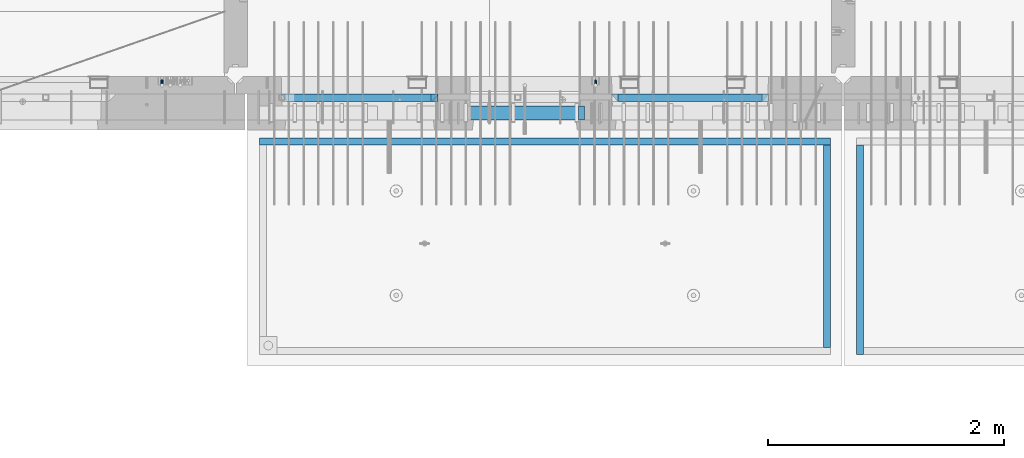
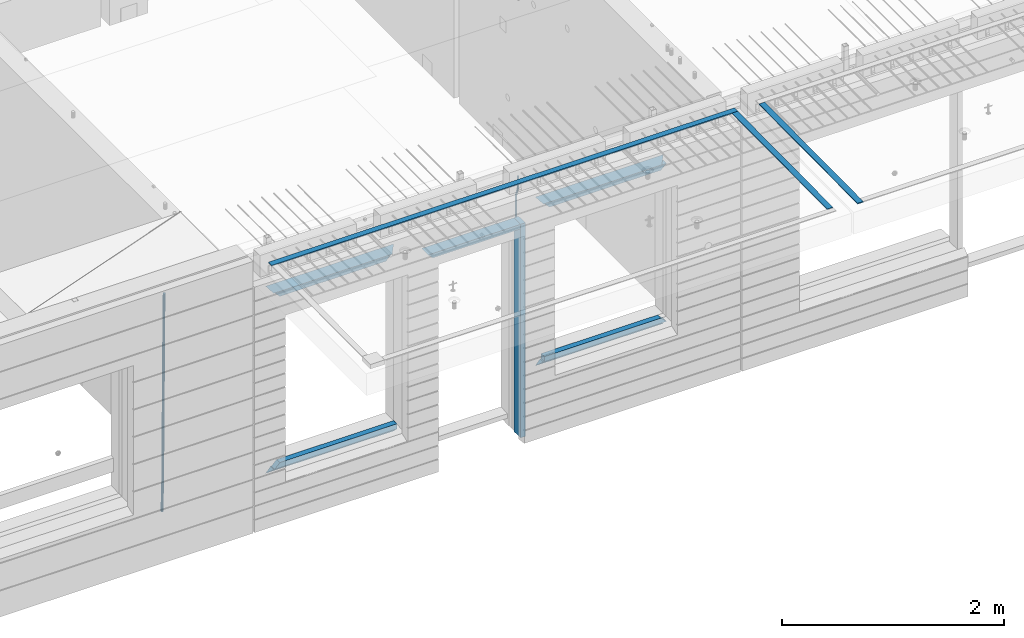
# One storey, part 96 of 349: 15 beams, 4 elements without a shape of their own.
"""IFC2X3 building model written with IfcOpenShell, lengths in millimetres."""

from ifc_helpers import new_model, si_unit, frame, origin_with_axes, place, context, subcontext, project, spatial, faceted_brep, material, type_object, element, aggregate, save


model = new_model("IFC2X3")

# Units and contexts
model_context = context("Model", 3, precision=1e-05, world=origin_with_axes())
body_context = subcontext(model_context, "Body", "Model", "MODEL_VIEW")
ifc_project = project(units=[si_unit("LENGTHUNIT", "METRE", prefix="MILLI"), si_unit("AREAUNIT", "SQUARE_METRE"), si_unit("VOLUMEUNIT", "CUBIC_METRE"), si_unit("MASSUNIT", "GRAM", prefix="KILO"), si_unit("TIMEUNIT", "SECOND"), si_unit("PLANEANGLEUNIT", "RADIAN"), si_unit("SOLIDANGLEUNIT", "STERADIAN"), si_unit("THERMODYNAMICTEMPERATUREUNIT", "DEGREE_CELSIUS"), si_unit("LUMINOUSINTENSITYUNIT", "LUMEN")], contexts=[model_context])

# Site, building, storey
site_placement = place(None, origin_with_axes())
site = spatial("IfcSite", under=ifc_project, at=site_placement, CompositionType="ELEMENT")
building_placement = place(site_placement, origin_with_axes())
building = spatial("IfcBuilding", under=site, at=building_placement, CompositionType="ELEMENT")
storey_placement = place(building_placement, origin_with_axes())
storey = spatial("IfcBuildingStorey", under=building, at=storey_placement, Name="4", CompositionType="ELEMENT", Elevation=0.0)

# Assembly, beam
assembly_1_placement = place(storey_placement, origin_with_axes())
assembly_1 = element("IfcElementAssembly", 1, at=assembly_1_placement, inside=storey, AssemblyPlace="NOTDEFINED", PredefinedType="REINFORCEMENT_UNIT")
ifc_material_1 = material()
beam_type_1 = type_object("IfcBeamType", Name="D20", PredefinedType="NOTDEFINED")
beam_1_placement = place(assembly_1_placement, frame((19710.0073333522, 7925.0, 93407.5000058722), z_axis=(0.000415599999849905, 0.999999913638203, 4.76000000899737e-07), x_axis=(0.0, 0.0, -1.0)))
beam_1 = element("IfcBeam", 2, at=beam_1_placement, type_object=beam_type_1, material=ifc_material_1, Name="JM20", ObjectType="D20", context=body_context, shape_type="Brep", body=[
    faceted_brep([(0.0, -10.0, 0.0), (-4.19531716033816e-08, -7.07106781186667, -7.07106781187031), (113.248091332178, -7.0710684840451, -7.0710678117357), (113.248091314759, -10.0000006713562, -2.51020537689328e-10), (0.0, 0.0, -10.0), (113.248091374131, -6.72178430249915e-07, -9.99999999986903), (4.196772351861e-08, 7.07106781186303, -7.07106781186667), (113.248091416113, 7.07106713968824, -7.07106781173934), (0.0, 10.0, 0.0), (113.248091433488, 9.99999932782521, 1.30967237055302e-10), (4.196772351861e-08, 7.07106781185939, 7.07106781185939), (113.248091416113, 7.0710671396846, 7.071067811994), (0.0, 0.0, 10.0), (113.248091374131, -6.72174792271107e-07, 10.0000000001273), (-4.19531716033816e-08, -7.07106781187031, 7.07106781185939), (113.248091332178, -7.0710684840451, 7.071067811994), (130.699843527167, -7.06993249763036, -4.33745683788584), (128.538066582521, -9.99900540317321, 2.39499413731755), (131.594536475241, 0.00119355250353692, -7.12624594330919), (130.698046432328, 7.07220300913468, -4.33773834422391), (128.535525107087, 10.0009944322555, 2.39459602660281), (126.373748162892, 7.07192152754578, 9.1270470011732), (125.479055214906, 0.000795477419160306, 11.9158361066184), (126.37554525779, -7.07021397921199, 9.12732850753673), (240.336258550378, -7.05529970173666, 30.8729495437874), (238.174481606227, -9.98437260450009, 37.6054005176375), (241.230951498423, 0.0158263482953771, 28.0841604381058), (240.334461455612, 7.0868358050102, 30.8726680369582), (238.171940130502, 10.0156272283348, 37.6050024077231), (236.010163186409, 7.08655432384694, 44.3374533824244), (235.115470238379, 0.0154282738185429, 47.1262424881097), (236.011960281176, -7.05558118289991, 44.3377348892536), (253.461915329972, -7.05444528127919, 32.9289287376414), (253.46191532613, -9.98337746617108, 39.9999965521893), (253.461915339081, 0.0166225284556276, 29.9999965443676), (253.461915348205, 7.08769034247234, 32.9289287273205), (253.461915352003, 10.0166225357716, 39.9999965370152), (253.461915348293, 7.08769035281148, 47.0710643509774), (253.461915339183, 0.0166225430875784, 49.999996544273), (253.46191533003, -7.05444527093641, 47.0710643613093), (1617.47998045172, -7.05444857276962, 32.9289287369675), (1617.47998044467, -9.98338075699212, 39.9999965504549), (1617.47998046874, 0.0166192374708771, 29.9999965449206), (1617.47998048575, 7.08768705096008, 32.9289287291404), (1617.47998049279, 10.0166192430079, 39.9999965393854), (1617.47998048575, 7.08768705878902, 47.071064352871), (1617.47998046874, 0.0166192485448846, 49.9999965449197), (1617.47998045172, -7.05444856494069, 47.0710643606981)], [[[0, 1, 2, 3]], [[1, 4, 5, 2]], [[4, 6, 7, 5]], [[6, 8, 9, 7]], [[8, 10, 11, 9]], [[10, 12, 13, 11]], [[12, 14, 15, 13]], [[14, 0, 3, 15]], [[14, 12, 10, 8, 6, 4, 1, 0]], [[3, 2, 16, 17]], [[2, 5, 18, 16]], [[5, 7, 19, 18]], [[7, 9, 20, 19]], [[9, 11, 21, 20]], [[11, 13, 22, 21]], [[13, 15, 23, 22]], [[15, 3, 17, 23]], [[17, 16, 24, 25]], [[16, 18, 26, 24]], [[18, 19, 27, 26]], [[19, 20, 28, 27]], [[20, 21, 29, 28]], [[21, 22, 30, 29]], [[22, 23, 31, 30]], [[23, 17, 25, 31]], [[25, 24, 32, 33]], [[24, 26, 34, 32]], [[26, 27, 35, 34]], [[27, 28, 36, 35]], [[28, 29, 37, 36]], [[29, 30, 38, 37]], [[30, 31, 39, 38]], [[31, 25, 33, 39]], [[33, 32, 40, 41]], [[32, 34, 42, 40]], [[34, 35, 43, 42]], [[35, 36, 44, 43]], [[36, 37, 45, 44]], [[37, 38, 46, 45]], [[38, 39, 47, 46]], [[39, 33, 41, 47]], [[42, 43, 44, 45, 46, 47, 41, 40]]]),
])

assembly_2_placement = place(storey_placement, origin_with_axes())
assembly_2 = element("IfcElementAssembly", 3, at=assembly_2_placement, inside=storey, AssemblyPlace="NOTDEFINED", PredefinedType="REINFORCEMENT_UNIT")
beam_type_2 = type_object("IfcBeamType", Name="D25", PredefinedType="NOTDEFINED")
beam_2_placement = place(assembly_2_placement, frame((16034.9999999961, 7965.00000227913, 90990.0), z_axis=(0.00020576299992186, -0.999642804629538, -0.0267249099901004), x_axis=(-4.30000201928125e-08, -0.0267249099948059, 0.999642825806181)))
beam_2 = element("IfcBeam", 4, at=beam_2_placement, type_object=beam_type_2, material=ifc_material_1, Name="JM25", ObjectType="D25", context=body_context, shape_type="Brep", body=[
    faceted_brep([(-7.41420080885291e-08, -12.5, -3.63797880709171e-12), (-6.42030499875546e-08, -10.8253175473074, -6.25000000000364), (60.4103898235917, -10.8253175318459, -6.2499999938409), (60.4103898269532, -12.4999999845422, 6.16273609921336e-09), (-3.70782800018787e-08, -6.25000000000364, -10.8253175473074), (60.4103898202884, -6.24999998454587, -10.8253175411446), (-1.45519152283669e-11, -3.63797880709171e-12, -12.5), (60.4103898179019, 1.54577719513327e-08, -12.4999999938373), (3.70637280866504e-08, 6.25, -10.8253175473074), (60.410389817087, 6.25000001545777, -10.825317541141), (6.42030499875546e-08, 10.8253175473001, -6.25000000000364), (60.410389818062, 10.8253175627578, -6.24999999383726), (7.41420080885291e-08, 12.4999999999927, 0.0), (60.4103898205503, 12.5000000154541, 6.16273609921336e-09), (6.42176019027829e-08, 10.8253175473001, 6.24999999999636), (60.4103898238973, 10.8253175627651, 6.2500000061591), (3.70928319171071e-08, 6.24999999999636, 10.8253175473037), (60.4103898272151, 6.25000001546141, 10.8253175534664), (1.45519152283669e-11, -3.63797880709171e-12, 12.4999999999964), (60.4103898296162, 1.54541339725256e-08, 12.5000000061591), (-3.7049176171422e-08, -6.25000000000364, 10.8253175473001), (60.4103898304165, -6.24999998454587, 10.8253175534701), (-6.41884980723262e-08, -10.8253175473074, 6.25), (60.4103898294561, -10.8253175318459, 6.25000000616637), (61.0324985728803, -10.8253175316895, -6.24999999377542), (60.991802792938, -12.4999999843931, 6.22458173893392e-09), (61.0622854283865, -6.24999998437852, -10.8253175410755), (61.0731819955545, 1.5628756955266e-08, -12.4999999937718), (61.0622685480339, 6.25000001562512, -10.8253175410791), (61.032469335245, 10.8253175629216, -6.24999999377178), (60.9917690322181, 12.5000000156033, 6.22458173893392e-09), (60.9510732522613, 10.8253175629034, 6.25000000621731), (60.9212863967696, 6.25000001558874, 10.8253175535247), (60.9103898296162, 1.55814632307738e-08, 12.5000000062137), (60.9213032771368, -6.24999998441126, 10.8253175535174), (60.9511024898966, -10.8253175317113, 6.25000000621731), (61.6545545670233, -10.8253158516927, -6.24189838219536), (61.573166454793, -12.499998414296, 0.00757164385504439), (61.7141257553885, -6.24999822394238, -10.8168280205282), (61.7359179680789, 1.80548886419274e-06, -12.491368569139), (61.7140919992817, 6.25000177601396, -10.8168282403167), (61.6544960997562, 10.8253192428383, -6.2418987628771), (61.5730989426083, 12.5000015856094, 0.0075712042817031), (61.4917108303925, 10.8253190230062, 6.25704123032847), (61.4321396420273, 6.25000139525582, 10.8319708686649), (61.4103474293224, 1.36582457344048e-06, 12.5065114172721), (61.4321733981196, -6.24999860470052, 10.8319710884571), (61.4917692976451, -10.8253160715249, 6.25704161101385), (176.524302641745, -10.8250056210964, -4.74584321979273), (176.442914529529, -12.4996881836996, 1.50362680625403), (176.583873830095, -6.24968799334965, -9.3207728581292), (176.605666042786, 0.000312036081595579, -10.9953134067364), (176.583840074018, 6.25031200660669, -9.32077307791769), (176.524244174492, 10.8256294734347, -4.74584360047811), (176.44284701733, 12.5003118162058, 1.50362636668069), (176.361458905099, 10.8256292535989, 7.75309639272746), (176.301887716749, 6.25031162585219, 12.3280260310676), (176.280095504058, 0.000311596420942806, 14.0025665796711), (176.301921472827, -6.24968837410415, 12.3280262508561), (176.361517372367, -10.8250058409321, 7.75309677341284), (177.085397012124, -10.8250041057399, -4.73853556792164), (176.983633547483, -12.4996867233749, 1.51066909103247), (177.159881729676, -6.24968643771717, -9.31327097355097), (177.187129580227, 0.000313606451527448, -10.987740468332), (177.159839524218, 6.25031356221734, -9.31327130338468), (177.085323910098, 10.8256309887511, -4.73853613920801), (176.983549136537, 12.5003132764905, 1.51066843136869), (176.881785671867, 10.8256306588555, 7.7598730903228), (176.80730095433, 6.25031299082912, 12.3346084959521), (176.780053103794, 0.000312946667690994, 14.0090779907332), (176.807343159802, -6.2496870091054, 12.3346088257895), (176.881858773908, -10.8250044356355, 7.7598736616128), (177.646431799818, -10.8250018318176, -4.72756919822132), (177.524295146417, -12.4996845320202, 1.52123723245313), (177.735828462886, -6.24968410334986, -9.30201312475765), (177.768531371941, 0.00031596292683389, -10.9763759912421), (177.735777808921, 6.25031589654827, -9.30201361973741), (177.646344064575, 10.8256332626152, -4.72757005553649), (177.524193838486, 12.5003154677688, 1.52123624250817), (177.402057185071, 10.8256327675663, 7.77004267317898), (177.312660521988, 6.2503150390985, 12.3444865997226), (177.279957612933, 0.00031497282179771, 14.0188494661961), (177.312711175953, -6.24968496079964, 12.3444870946951), (177.402144920314, -10.8250023268702, 7.77004353049415), (299.377443161706, -10.8245084454466, -2.34813158632096), (299.255306508276, -12.4991911456491, 3.90067484435349), (299.466839824803, -6.24919071697514, -6.92257551286093), (299.499542733873, 0.0008093492979242, -8.59693837933446), (299.466789170867, 6.250809282923, -6.92257600783341), (299.377355426492, 10.8261266489935, -2.34813244364341), (299.255205200388, 12.5008088541435, 3.90067385440125), (299.133068546944, 10.826126153941, 10.1494802850757), (299.043671883861, 6.25080842546959, 14.7239242116229), (299.010968974762, 0.000808359200163977, 16.3982870780892), (299.043722537797, -6.24919157442127, 14.7239247065918), (299.133156282158, -10.8245089404954, 10.1494811423981), (299.98561436501, -10.8245059804758, -2.33624385599614), (299.97179243555, -12.4991882411778, 3.91467976726199), (299.995742293278, -6.24918857328521, -6.91223722345239), (299.999447243041, 0.000811375455668895, -8.58716690387519), (299.995736475976, 6.25081142679483, -6.91223684201032), (299.985604289133, 10.8261291142808, -2.33624319533556), (299.971750386685, 12.5008117588586, 3.91467993563856), (299.957928457196, 10.8261294971744, 10.1656035610831), (299.947800528913, 6.25081208998381, 14.7415969285394), (299.944095579151, 0.00081214124293183, 16.4165266089549), (299.947806346216, -6.24918791008895, 14.7415965471009), (299.957938533058, -10.8245055975785, 10.1656029004225), (300.593832239858, -10.8245078794353, -2.34543881707941), (300.688302931099, -12.4991904788549, 3.90384712594823), (300.524685350189, -6.24919022474205, -6.92023371784308), (300.499390115292, 0.000809814544481924, -8.59472497713432), (300.524724372954, 6.25080977519247, -6.92023401429469), (300.593899829313, 10.8261272150703, -2.34543933054374), (300.688380976673, 12.5008095210287, 3.90384653304136), (300.782851667915, 10.8261269216127, 10.1531324760799), (300.851998557599, 6.25080926691589, 14.7279273768363), (300.877293792495, 0.000809227632998955, 16.4024186361276), (300.851959534804, -6.24919073302226, 14.7279276732806), (300.782784078474, -10.8245081728965, 10.153132989537), (2293.32930409742, -10.8307295605009, -32.4713622331001), (2293.42377478865, -12.5054121599169, -26.2220762900724), (2293.26015720774, -6.2554119058077, -37.0461571338565), (2293.23486197284, -0.00541186651753378, -38.7206483931477), (2293.26019623051, 6.24458809413409, -37.0461574303008), (2293.32937168686, 10.8199055340046, -32.4713627465644), (2293.42385283421, 12.4945878399631, -26.2220768829684), (2293.51832352545, 10.8199052405434, -19.972790939948), (2293.58747041514, 6.24458758585388, -15.3979960391844), (2293.61276565003, -0.00541245343265473, -13.7235047798931), (2293.58743139236, -6.25541241408428, -15.3979957427327), (2293.51825593603, -10.8307298539585, -19.9727904264691), (2294.0420846676, -10.8307317859326, -32.4821379598216), (2294.03681932652, -12.5054140739521, -26.2313442200393), (2294.06778164886, -6.2554144273563, -37.0583666982457), (2294.10702478497, -0.00541458957013674, -38.7338336404937), (2294.14929890928, 6.24458531819619, -37.0595987724118), (2294.18327670435, 10.8199028679592, -32.4842719748667), (2294.1998538474, 12.4945854171456, -26.2338083683717), (2294.19458850632, 10.819903129126, -19.9830146285858), (2294.16889152506, 6.24458577054975, -15.4067858901581), (2294.12964838895, -0.0054140672327776, -13.7313189479173), (2294.08737426462, -6.2554139749991, -15.4055538159919), (2294.05339646956, -10.8307315247621, -19.9808806135297), (2294.75482297382, -10.84002603931, -32.4726521173216), (2294.64982751427, -12.513407826169, -26.2231856868602), (2294.87535820232, -6.26594539088183, -37.0476186524102), (2294.97913588268, -0.0167870967634371, -38.7222267036377), (2295.0383488692, 6.23299192477134, -37.0477663960555), (2295.03713108998, 10.8087684320271, -32.4729080168181), (2294.97580884799, 12.4844668051373, -26.2234811741473), (2294.87081338844, 10.8110850182784, -19.9740147436787), (2294.7502781599, 6.23700436985018, -15.3990482086047), (2294.64650047956, -0.0121539242718427, -13.7244401573698), (2294.58728749304, -6.26193294580662, -15.3989004649666), (2294.58850527227, -10.8377094530588, -19.9737588441894), (2316.44667268227, -11.1228921988077, -32.1839550346631), (2316.34167722271, -12.7962739856739, -25.9344886042054), (2316.56720791078, -6.54881155039038, -36.7589215697517), (2316.67098559113, -0.299653256264719, -38.4335296209792), (2316.73019857766, 5.95012576527006, -36.759069313397), (2316.72898079845, 10.5259022725259, -32.1842109341669), (2316.66765855643, 12.2016006456361, -25.9347840914961), (2316.56266309689, 10.5282188587698, -19.6853176610275), (2316.44212786836, 5.95413821035254, -15.1103511259389), (2316.33835018802, -0.295020083769487, -13.4357430747186), (2316.27913720149, -6.54479910530426, -15.1102033823008), (2316.28035498071, -11.1205756125637, -19.685061761531), (2317.13234804722, -11.1318335458927, -32.1748293731798), (2317.04181141085, -12.8054038787741, -25.9251705100723), (2317.2154741603, -6.5572650749491, -36.7502937866229), (2317.26891617525, -0.307450393454928, -38.4255717558117), (2317.27835434731, 5.94297770185585, -36.7517739018112), (2317.24125972588, 10.5192220504723, -32.1773930078925), (2317.16757178486, 12.1950816748285, -25.9281307404563), (2317.0770351485, 10.5215113419545, -19.6784718773561), (2316.99390903539, 5.94694287101083, -15.1030074639057), (2316.94046702047, -0.302871810494253, -13.4277294947169), (2316.9310288484, -6.55329990579412, -15.1015273487101), (2316.96812346982, -11.1295442544142, -19.6759082426288), (2317.81808136747, -11.1298054502913, -32.1659056455355), (2317.74200467508, -12.803315894289, -25.9160547315114), (2317.86379538118, -6.55536082026447, -36.7418676070083), (2317.8668976831, -0.305700748642266, -38.417815303761), (2317.82655701396, 5.94458339541234, -36.7446799039099), (2317.75358262347, 10.5207330230332, -32.1707766866384), (2317.66752794063, 12.1965725370646, -25.9216793252963), (2317.59145124823, 10.5230620930706, -19.6718284112721), (2317.54573723453, 5.94861746304377, -15.0958664497994), (2317.54263493262, -0.301042608574789, -13.4199187530394), (2317.58297560175, -6.55132675263303, -15.0930541529051), (2317.65594999224, -11.1274763802539, -19.6669573701693), (2417.81884292323, -10.831603083323, -30.8687911350135), (2417.74276623082, -12.505113527317, -24.618940220982), (2417.86455693691, -6.25715845329614, -35.4447530964935), (2417.86765923884, -0.00749838167394046, -37.1207007932499), (2417.82731856969, 6.24278576237703, -35.4475653933878), (2417.75434417921, 10.8189353900088, -30.8736621761236), (2417.66828949639, 12.494774904033, -24.6245648147851), (2417.59221280397, 10.8212644600353, -18.3747139007501), (2417.54649879028, 6.2468198300121, -13.79875193927), (2417.54339648837, -0.00284024161010166, -12.1228042425173), (2417.5837371575, -6.25312438566107, -13.795939642383), (2417.65671154798, -10.8292740132893, -18.3698428596399)], [[[0, 1, 2, 3]], [[1, 4, 5, 2]], [[4, 6, 7, 5]], [[6, 8, 9, 7]], [[8, 10, 11, 9]], [[10, 12, 13, 11]], [[12, 14, 15, 13]], [[14, 16, 17, 15]], [[16, 18, 19, 17]], [[18, 20, 21, 19]], [[20, 22, 23, 21]], [[22, 0, 3, 23]], [[22, 20, 18, 16, 14, 12, 10, 8, 6, 4, 1, 0]], [[3, 2, 24, 25]], [[2, 5, 26, 24]], [[5, 7, 27, 26]], [[7, 9, 28, 27]], [[9, 11, 29, 28]], [[11, 13, 30, 29]], [[13, 15, 31, 30]], [[15, 17, 32, 31]], [[17, 19, 33, 32]], [[19, 21, 34, 33]], [[21, 23, 35, 34]], [[23, 3, 25, 35]], [[25, 24, 36, 37]], [[24, 26, 38, 36]], [[26, 27, 39, 38]], [[27, 28, 40, 39]], [[28, 29, 41, 40]], [[29, 30, 42, 41]], [[30, 31, 43, 42]], [[31, 32, 44, 43]], [[32, 33, 45, 44]], [[33, 34, 46, 45]], [[34, 35, 47, 46]], [[35, 25, 37, 47]], [[37, 36, 48, 49]], [[36, 38, 50, 48]], [[38, 39, 51, 50]], [[39, 40, 52, 51]], [[40, 41, 53, 52]], [[41, 42, 54, 53]], [[42, 43, 55, 54]], [[43, 44, 56, 55]], [[44, 45, 57, 56]], [[45, 46, 58, 57]], [[46, 47, 59, 58]], [[47, 37, 49, 59]], [[49, 48, 60, 61]], [[48, 50, 62, 60]], [[50, 51, 63, 62]], [[51, 52, 64, 63]], [[52, 53, 65, 64]], [[53, 54, 66, 65]], [[54, 55, 67, 66]], [[55, 56, 68, 67]], [[56, 57, 69, 68]], [[57, 58, 70, 69]], [[58, 59, 71, 70]], [[59, 49, 61, 71]], [[61, 60, 72, 73]], [[60, 62, 74, 72]], [[62, 63, 75, 74]], [[63, 64, 76, 75]], [[64, 65, 77, 76]], [[65, 66, 78, 77]], [[66, 67, 79, 78]], [[67, 68, 80, 79]], [[68, 69, 81, 80]], [[69, 70, 82, 81]], [[70, 71, 83, 82]], [[71, 61, 73, 83]], [[73, 72, 84, 85]], [[72, 74, 86, 84]], [[74, 75, 87, 86]], [[75, 76, 88, 87]], [[76, 77, 89, 88]], [[77, 78, 90, 89]], [[78, 79, 91, 90]], [[79, 80, 92, 91]], [[80, 81, 93, 92]], [[81, 82, 94, 93]], [[82, 83, 95, 94]], [[83, 73, 85, 95]], [[85, 84, 96, 97]], [[84, 86, 98, 96]], [[86, 87, 99, 98]], [[87, 88, 100, 99]], [[88, 89, 101, 100]], [[89, 90, 102, 101]], [[90, 91, 103, 102]], [[91, 92, 104, 103]], [[92, 93, 105, 104]], [[93, 94, 106, 105]], [[94, 95, 107, 106]], [[95, 85, 97, 107]], [[97, 96, 108, 109]], [[96, 98, 110, 108]], [[98, 99, 111, 110]], [[99, 100, 112, 111]], [[100, 101, 113, 112]], [[101, 102, 114, 113]], [[102, 103, 115, 114]], [[103, 104, 116, 115]], [[104, 105, 117, 116]], [[105, 106, 118, 117]], [[106, 107, 119, 118]], [[107, 97, 109, 119]], [[109, 108, 120, 121]], [[108, 110, 122, 120]], [[110, 111, 123, 122]], [[111, 112, 124, 123]], [[112, 113, 125, 124]], [[113, 114, 126, 125]], [[114, 115, 127, 126]], [[115, 116, 128, 127]], [[116, 117, 129, 128]], [[117, 118, 130, 129]], [[118, 119, 131, 130]], [[119, 109, 121, 131]], [[121, 120, 132, 133]], [[120, 122, 134, 132]], [[122, 123, 135, 134]], [[123, 124, 136, 135]], [[124, 125, 137, 136]], [[125, 126, 138, 137]], [[126, 127, 139, 138]], [[127, 128, 140, 139]], [[128, 129, 141, 140]], [[129, 130, 142, 141]], [[130, 131, 143, 142]], [[131, 121, 133, 143]], [[133, 132, 144, 145]], [[132, 134, 146, 144]], [[134, 135, 147, 146]], [[135, 136, 148, 147]], [[136, 137, 149, 148]], [[137, 138, 150, 149]], [[138, 139, 151, 150]], [[139, 140, 152, 151]], [[140, 141, 153, 152]], [[141, 142, 154, 153]], [[142, 143, 155, 154]], [[143, 133, 145, 155]], [[145, 144, 156, 157]], [[144, 146, 158, 156]], [[146, 147, 159, 158]], [[147, 148, 160, 159]], [[148, 149, 161, 160]], [[149, 150, 162, 161]], [[150, 151, 163, 162]], [[151, 152, 164, 163]], [[152, 153, 165, 164]], [[153, 154, 166, 165]], [[154, 155, 167, 166]], [[155, 145, 157, 167]], [[157, 156, 168, 169]], [[156, 158, 170, 168]], [[158, 159, 171, 170]], [[159, 160, 172, 171]], [[160, 161, 173, 172]], [[161, 162, 174, 173]], [[162, 163, 175, 174]], [[163, 164, 176, 175]], [[164, 165, 177, 176]], [[165, 166, 178, 177]], [[166, 167, 179, 178]], [[167, 157, 169, 179]], [[169, 168, 180, 181]], [[168, 170, 182, 180]], [[170, 171, 183, 182]], [[171, 172, 184, 183]], [[172, 173, 185, 184]], [[173, 174, 186, 185]], [[174, 175, 187, 186]], [[175, 176, 188, 187]], [[176, 177, 189, 188]], [[177, 178, 190, 189]], [[178, 179, 191, 190]], [[179, 169, 181, 191]], [[181, 180, 192, 193]], [[180, 182, 194, 192]], [[182, 183, 195, 194]], [[183, 184, 196, 195]], [[184, 185, 197, 196]], [[185, 186, 198, 197]], [[186, 187, 199, 198]], [[187, 188, 200, 199]], [[188, 189, 201, 200]], [[189, 190, 202, 201]], [[190, 191, 203, 202]], [[191, 181, 193, 203]], [[194, 195, 196, 197, 198, 199, 200, 201, 202, 203, 193, 192]]]),
])
aggregate(assembly_2, [beam_2])

assembly_3_placement = place(storey_placement, origin_with_axes())
assembly_3 = element("IfcElementAssembly", 5, at=assembly_3_placement, inside=storey, AssemblyPlace="NOTDEFINED", PredefinedType="REINFORCEMENT_UNIT")
ifc_material_2 = material(Name="CONCRETE/Concrete_Undefined")
beam_type_3 = type_object("IfcBeamType", PredefinedType="NOTDEFINED")
beam_3_placement = place(assembly_3_placement, frame((21949.9413897781, 7420.05314849477, 93725.6636561746), z_axis=(2.93000000986506e-07, -0.00901322400064496, 0.999959380071525), x_axis=(3.25389999851993e-05, -0.999959379542196, -0.00901322399586982)))
beam_3 = element("IfcBeam", 6, at=beam_3_placement, type_object=beam_type_3, material=ifc_material_2, context=body_context, shape_type="Brep", body=[
    faceted_brep([(2.5465851649642e-11, 29.9999999999982, -4.99999999998545), (-2.91038304567337e-11, 29.9999999999982, 5.0), (1775.16788460852, 30.0000000000036, 5.0), (1775.16788460861, 30.0000000000036, -4.99999999998545), (-2.5465851649642e-11, -30.0000000000018, 5.0), (1775.16788460852, -29.9999999999927, 5.0), (2.72848410531878e-11, -30.0000000000018, -4.99999999998545), (1775.16788460861, -29.9999999999927, -4.99999999998545)], [[[0, 1, 2, 3]], [[1, 4, 5, 2]], [[4, 6, 7, 5]], [[6, 0, 3, 7]], [[5, 7, 3, 2]], [[6, 4, 1, 0]]]),
])
aggregate(assembly_3, [beam_3])

# Assembly, beams
assembly_4_placement = place(storey_placement, origin_with_axes())
assembly_4 = element("IfcElementAssembly", 7, at=assembly_4_placement, inside=storey, AssemblyPlace="NOTDEFINED", PredefinedType="REINFORCEMENT_UNIT")
beam_4_placement = place(assembly_4_placement, frame((21670.0013901233, 7419.93998011425, 93723.2790373903), z_axis=(-5.99999839176643e-09, -0.0089070149978186, 0.99996033175513), x_axis=(-7.26999998800451e-07, -0.999960331754865, -0.00890701499781462)))
beam_4 = element("IfcBeam", 8, at=beam_4_placement, type_object=beam_type_3, material=ifc_material_2, context=body_context, shape_type="Brep", body=[
    faceted_brep([(2.5465851649642e-11, 29.9999999999982, -4.99999999998545), (-2.91038304567337e-11, 29.9999999999982, 5.0), (1714.98205429674, 30.0, 5.00000000001455), (1714.98205429674, 30.0000000000036, -4.99999999998545), (-2.5465851649642e-11, -30.0000000000018, 5.0), (1714.98205429674, -30.0, 5.00000000001455), (2.72848410531878e-11, -30.0000000000018, -4.99999999998545), (1714.98205429674, -29.9999999999964, -4.99999999998545)], [[[0, 1, 2, 3]], [[1, 4, 5, 2]], [[4, 6, 7, 5]], [[6, 0, 3, 7]], [[5, 7, 3, 2]], [[6, 4, 1, 0]]]),
])
beam_5_placement = place(assembly_4_placement, frame((21700.0027302922, 7449.93184428734, 93723.6588442717), z_axis=(0.0, 0.0, 1.0), x_axis=(-0.999999999888168, 1.49249999983396e-05, 9.53000001204034e-07)))
beam_5 = element("IfcBeam", 9, at=beam_5_placement, type_object=beam_type_3, material=ifc_material_2, context=body_context, shape_type="Brep", body=[
    faceted_brep([(2.5465851649642e-11, 29.9999999999982, -4.99999999998545), (-2.91038304567337e-11, 29.9999999999982, 5.0), (4840.00999799337, 29.9999999999991, 5.0), (4840.00999799337, 29.9999999999982, -5.00000000001455), (-2.5465851649642e-11, -30.0000000000018, 5.0), (4840.00999799337, -30.0000000000009, 5.0), (2.72848410531878e-11, -30.0000000000018, -4.99999999998545), (4840.00999799337, -30.0000000000009, -5.0)], [[[0, 1, 2, 3]], [[1, 4, 5, 2]], [[4, 6, 7, 5]], [[6, 0, 3, 7]], [[5, 7, 3, 2]], [[6, 4, 1, 0]]]),
])
aggregate(assembly_4, [beam_4, beam_5])

# Beam
ifc_material_3 = material(Name="CONCRETE/C35/45")
beam_type_4 = type_object("IfcBeamType", PredefinedType="NOTDEFINED")
beam_6_placement = place(assembly_1_placement, frame((17044.9994828029, 7820.0, 93145.0), z_axis=(0.0, 0.0, -1.0), x_axis=(1.0, 0.0, 0.0)))
beam_6 = element("IfcBeam", 10, at=beam_6_placement, type_object=beam_type_4, material=ifc_material_3, Name="SK", context=body_context, shape_type="Brep", body=[
    faceted_brep([(0.0, -30.0, -30.0), (49.817662327685, -30.0, 30.0), (49.817662327685, 30.0, 30.0), (1330.00114440918, -30.0, -30.0), (1280.18348208149, -30.0, 30.0), (1280.18348208149, 30.0, 30.0)], [[[0, 1, 2]], [[1, 0, 3, 4]], [[2, 1, 4, 5]], [[0, 2, 5, 3]], [[4, 3, 5]]]),
])

beam_7_placement = place(assembly_1_placement, frame((17104.9994828029, 7820.0, 93085.0), z_axis=(0.0, 0.0, -1.0), x_axis=(1.0, 0.0, 0.0)))
beam_7 = element("IfcBeam", 11, at=beam_7_placement, type_object=beam_type_4, material=ifc_material_3, Name="SK", context=body_context, shape_type="Brep", body=[
    faceted_brep([(0.0, -30.0, -30.0), (53.0959879499314, -30.0, 24.0540540540678), (54.6888675884184, 30.0, 25.6756756756804), (0.0, 30.0, -30.0), (1210.00114440918, -30.0, -30.0), (1156.90515645927, -30.0, 24.0540540540678), (1155.31227682078, 30.0, 25.6756756756804), (1210.00114440918, 30.0, -30.0)], [[[0, 1, 2, 3]], [[1, 0, 4, 5]], [[2, 1, 5, 6]], [[3, 2, 6, 7]], [[0, 3, 7, 4]], [[6, 5, 4, 7]]]),
])

beam_8_placement = place(assembly_1_placement, frame((18375.0006272121, 7820.0, 91150.0), z_axis=(0.0, 0.0, 1.0), x_axis=(-1.0, 3.00000001838171e-08, 0.0)))
beam_8 = element("IfcBeam", 12, at=beam_8_placement, type_object=beam_type_4, material=ifc_material_3, Name="SK", context=body_context, shape_type="Brep", body=[
    faceted_brep([(0.0, -30.0, 30.0), (-5.28234522789717e-09, 30.0, 30.0), (0.0, -30.0, -30.0), (1280.18348208149, -30.0, 30.0), (1280.18348208149, 30.0, 30.0), (1330.00114440918, -30.0, -30.0)], [[[0, 1, 2]], [[1, 0, 3, 4]], [[2, 1, 4, 5]], [[0, 2, 5, 3]], [[3, 5, 4]]]),
])

beam_9_placement = place(assembly_1_placement, frame((18375.0006272121, 7820.0, 91210.0), z_axis=(0.0, 0.0, 1.0), x_axis=(-1.0, 3.00000001838171e-08, 0.0)))
beam_9 = element("IfcBeam", 13, at=beam_9_placement, type_object=beam_type_4, material=ifc_material_3, Name="SK", context=body_context, shape_type="Brep", body=[
    faceted_brep([(0.0, -30.0, -30.0), (0.0, -30.0, 30.0), (-5.28234522789717e-09, 30.0, 30.0), (0.0, 30.0, -30.0), (4.05405405405327, -30.0, 30.0), (5.67567567567312, 30.0, 30.0), (4.05405405404963, -30.0, 24.0540540540533), (5.67567567567312, 30.0, 25.6756756756804), (1215.31227682077, 30.0, 25.6756756756804), (1270.00114440918, 30.0, -30.0), (1270.00114440918, -30.0, -30.0), (1216.90515645926, -30.0, 24.0540540540678)], [[[0, 1, 2, 3]], [[2, 1, 4, 5]], [[4, 6, 7, 5]], [[3, 2, 5, 7, 8, 9]], [[0, 3, 9, 10]], [[6, 4, 1, 0, 10, 11]], [[7, 6, 11, 8]], [[10, 9, 8, 11]]]),
])

beam_10_placement = place(assembly_1_placement, frame((19845.0006272121, 7820.0, 93145.0), z_axis=(0.0, 0.0, -1.0), x_axis=(1.0, 0.0, 0.0)))
beam_10 = element("IfcBeam", 14, at=beam_10_placement, type_object=beam_type_4, material=ifc_material_3, Name="SK", context=body_context, shape_type="Brep", body=[
    faceted_brep([(0.0, -30.0, -30.0), (49.817662327685, -30.0, 30.0), (49.817662327685, 30.0, 30.0), (1329.99923706055, -30.0, -30.0), (1280.18157473286, -30.0, 30.0), (1280.18157473286, 30.0, 30.0)], [[[0, 1, 2]], [[1, 0, 3, 4]], [[2, 1, 4, 5]], [[0, 2, 5, 3]], [[4, 3, 5]]]),
])

beam_11_placement = place(assembly_1_placement, frame((19905.0006272121, 7820.0, 93085.0), z_axis=(0.0, 0.0, -1.0), x_axis=(1.0, 0.0, 0.0)))
beam_11 = element("IfcBeam", 15, at=beam_11_placement, type_object=beam_type_4, material=ifc_material_3, Name="SK", context=body_context, shape_type="Brep", body=[
    faceted_brep([(0.0, -30.0, -30.0), (53.0959879499314, -30.0, 24.0540540540678), (54.6888675884184, 30.0, 25.6756756756804), (0.0, 30.0, -30.0), (1269.99923706055, -30.0, -30.0), (1211.91971158142, -30.0, 24.0540540540533), (1210.17732581704, 30.0, 25.6756756756804), (1269.99923706055, 30.0, -30.0)], [[[0, 1, 2, 3]], [[1, 0, 4, 5]], [[2, 1, 5, 6]], [[3, 2, 6, 7]], [[0, 3, 7, 4]], [[6, 5, 4, 7]]]),
])

beam_12_placement = place(assembly_1_placement, frame((21174.9998642727, 7820.0, 91350.0), z_axis=(0.0, 0.0, 1.0), x_axis=(-1.0, 3.00000001838171e-08, 0.0)))
beam_12 = element("IfcBeam", 16, at=beam_12_placement, type_object=beam_type_4, material=ifc_material_3, Name="SK", context=body_context, shape_type="Brep", body=[
    faceted_brep([(1280.18157473286, -30.0, 30.0), (1329.99923706055, -30.0, -30.0), (1280.18157473286, 30.0, 30.0), (0.0, -30.0, -30.0), (49.817662327685, 30.0, 30.0), (49.817662327685, -30.0, 30.0)], [[[0, 1, 2]], [[3, 4, 2, 1]], [[4, 5, 0, 2]], [[5, 3, 1, 0]], [[3, 5, 4]]]),
])

beam_13_placement = place(assembly_1_placement, frame((21174.9998642727, 7820.0, 91410.0), z_axis=(0.0, 0.0, 1.0), x_axis=(-1.0, 3.00000001838171e-08, 0.0)))
beam_13 = element("IfcBeam", 17, at=beam_13_placement, type_object=beam_type_4, material=ifc_material_3, Name="SK", context=body_context, shape_type="Brep", body=[
    faceted_brep([(1269.99923706055, -30.0, -30.0), (1269.99923706055, 30.0, -30.0), (1269.99923706055, 30.0, 25.6756756756804), (1269.99923706055, -30.0, 24.0540540540678), (0.0, -30.0, -30.0), (0.0, 30.0, -30.0), (59.8219112435072, 30.0, 25.6756756756804), (58.0795254791192, -30.0, 24.0540540540533)], [[[0, 1, 2, 3]], [[4, 5, 1, 0]], [[2, 1, 5, 6]], [[3, 2, 6, 7]], [[0, 3, 7, 4]], [[6, 5, 4, 7]]]),
])

ifc_material_4 = material(Name="TIMBER")
beam_type_5 = type_object("IfcBeamType", Name="50X120", PredefinedType="NOTDEFINED")
beam_14_placement = place(assembly_1_placement, frame((18604.9998642727, 7690.0, 93080.0), z_axis=(0.0, 0.0, -1.0), x_axis=(1.0, 0.0, 0.0)))
beam_14 = element("IfcBeam", 18, at=beam_14_placement, type_object=beam_type_5, material=ifc_material_4, ObjectType="50X120", context=body_context, shape_type="Brep", body=[
    faceted_brep([(1009.99961853027, -60.0, 25.0), (1009.99961853027, -60.0, -25.0), (1009.99961853027, 60.0, -25.0), (1009.99961853027, 60.0, 25.0), (50.0000000000036, -60.0, 25.0), (0.0, -60.0, -25.0), (0.0, 60.0, -25.0), (50.0000000000036, 60.0, 25.0)], [[[0, 1, 2, 3]], [[1, 0, 4, 5]], [[2, 1, 5, 6]], [[3, 2, 6, 7]], [[0, 3, 7, 4]], [[6, 5, 4, 7]]]),
])

beam_15_placement = place(assembly_1_placement, frame((19589.9994828029, 7690.0, 93105.0), z_axis=(-1.0, 3.00000001838171e-08, 0.0), x_axis=(0.0, 0.0, -1.0)))
beam_15 = element("IfcBeam", 19, at=beam_15_placement, type_object=beam_type_5, material=ifc_material_4, ObjectType="50X120", context=body_context, shape_type="Brep", body=[
    faceted_brep([(0.0, 60.0, -25.0), (0.0, 60.0, 25.0), (2345.0, 60.0, 25.0), (2345.0, 60.0, -25.0), (0.0, -60.0, 25.0), (2345.0, -60.0, 25.0), (0.0, -60.0, -25.0), (2345.0, -60.0, -25.0)], [[[0, 1, 2, 3]], [[1, 4, 5, 2]], [[4, 6, 7, 5]], [[6, 0, 3, 7]], [[5, 7, 3, 2]], [[6, 4, 1, 0]]]),
])

aggregate(assembly_1, [beam_14, beam_15, beam_1, beam_6, beam_7, beam_8, beam_9, beam_10, beam_11, beam_12, beam_13])

save(model, "model.ifc")
